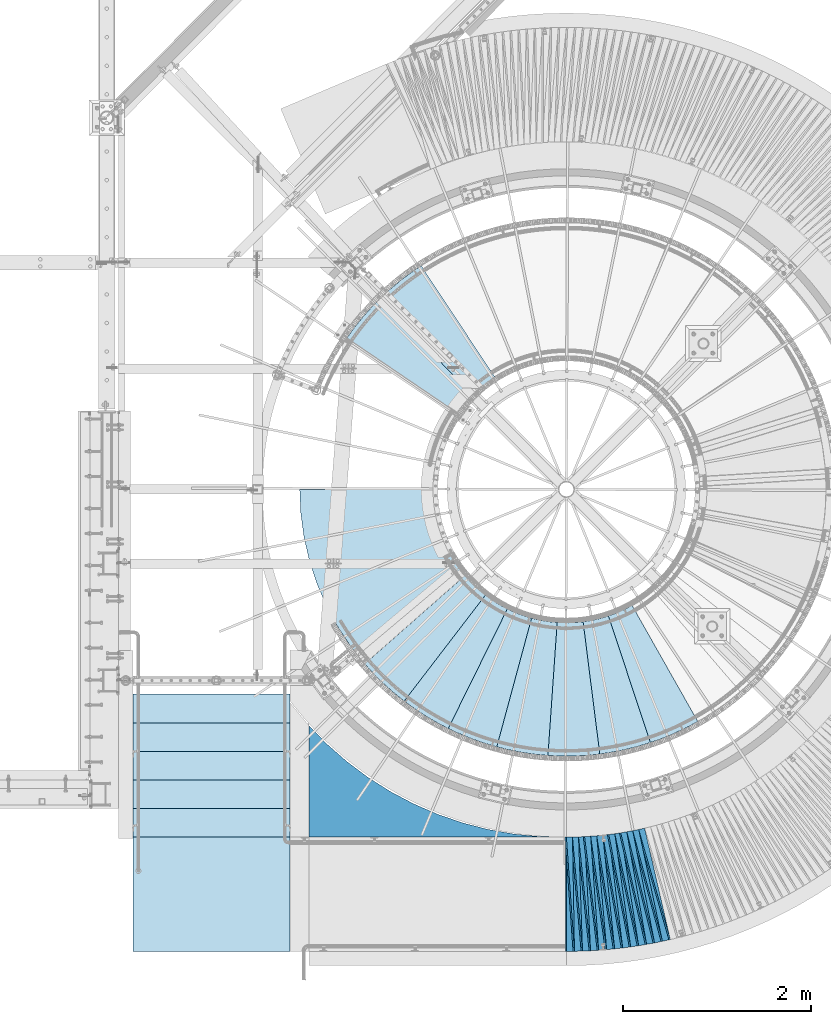
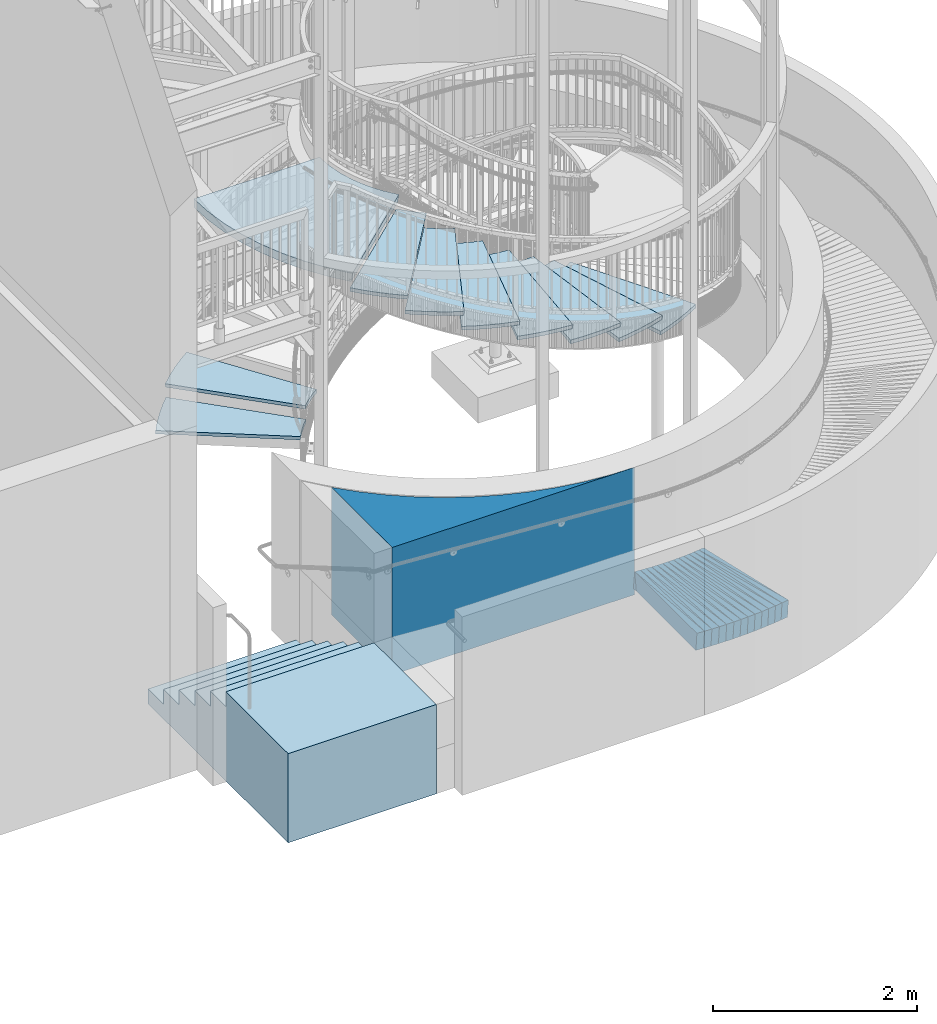
# One storey, part 830 of 975: 37 plates, 1 slab.
"""IFC2X3 building model written with IfcOpenShell, lengths in millimetres."""

from ifc_helpers import new_model, si_unit, frame, origin_with_axes, place, context, subcontext, project, spatial, faceted_brep, material, type_object, element, save


model = new_model("IFC2X3")

# Units and contexts
model_context = context("Model", 3, precision=1e-05, world=origin_with_axes())
body_context = subcontext(model_context, "Body", "Model", "MODEL_VIEW")
ifc_project = project(units=[si_unit("LENGTHUNIT", "METRE", prefix="MILLI"), si_unit("AREAUNIT", "SQUARE_METRE"), si_unit("VOLUMEUNIT", "CUBIC_METRE"), si_unit("MASSUNIT", "GRAM", prefix="KILO"), si_unit("TIMEUNIT", "SECOND"), si_unit("PLANEANGLEUNIT", "RADIAN"), si_unit("SOLIDANGLEUNIT", "STERADIAN"), si_unit("THERMODYNAMICTEMPERATUREUNIT", "DEGREE_CELSIUS"), si_unit("LUMINOUSINTENSITYUNIT", "LUMEN")], contexts=[model_context])

# Site, building, storey
site_placement = place(None, origin_with_axes())
site = spatial("IfcSite", under=ifc_project, at=site_placement, CompositionType="ELEMENT")
building_placement = place(site_placement, origin_with_axes())
building = spatial("IfcBuilding", under=site, at=building_placement, Name="Undefined", CompositionType="ELEMENT")
storey_placement = place(building_placement, origin_with_axes())
storey = spatial("IfcBuildingStorey", under=building, at=storey_placement, Name="Undefined", CompositionType="ELEMENT", Elevation=0.0)

# Plates
ifc_material_1 = material(Name="STEEL/A36")
plate_type_1 = type_object("IfcPlateType", PredefinedType="NOTDEFINED")
plate_1_placement = place(storey_placement, frame((34814.8418085716, -1523.26583017897, 780.818173331098), z_axis=(-0.99589164463732, -0.0705695748132342, 0.0567429929793393), x_axis=(-0.070455570976701, 0.997506859670101, 0.00400966699867388)))
element("IfcPlate", 1, at=plate_1_placement, inside=storey, type_object=plate_type_1, material=ifc_material_1, Name="SLAB", context=body_context, shape_type="Brep", body=[
    faceted_brep([(-6.82121026329696e-12, -100.000000000011, -1.09139364212751e-10), (6.07882642743971, -100.00000000003, 85.9247207637527), (6.07882642745199, 99.9999999999914, 85.924720763971), (5.91171556152403e-12, 100.000000000011, 1.09139364212751e-10), (1222.04675292938, -100.00000000011, -3.06317815557122e-09), (1222.04675292939, 99.9999999999113, -2.8521753847599e-09)], [[[0, 1, 2, 3]], [[1, 4, 5, 2]], [[4, 0, 3, 5]], [[5, 3, 2]], [[4, 1, 0]]]),
])
plate_2_placement = place(storey_placement, frame((34900.7386726768, -1520.36481451429, 775.918401585438), z_axis=(-0.994509342237145, -0.0879026625190699, 0.0567828330140366), x_axis=(-0.0878165980406093, 0.996128572460613, 0.00401400500185607)))
element("IfcPlate", 2, at=plate_2_placement, inside=storey, type_object=plate_type_1, material=ifc_material_1, Name="SLAB", context=body_context, shape_type="Brep", body=[
    faceted_brep([(-6.82121026329696e-12, -100.000000000011, -1.09139364212751e-10), (4.57472848894577, -99.9999999999877, 85.9702987673227), (4.57472848886573, 99.9999999999723, 85.9702987666024), (5.91171556152403e-12, 100.000000000011, 1.09139364212751e-10), (1220.72595214823, -100.000000000076, -8.80390871316195e-10), (1220.72595214815, 99.9999999998836, -1.59343471750617e-09)], [[[0, 1, 2, 3]], [[1, 4, 5, 2]], [[4, 0, 3, 5]], [[5, 3, 2]], [[4, 1, 0]]]),
])
plate_3_placement = place(storey_placement, frame((34986.633147639, -1517.46759381437, 770.924628633899), z_axis=(-0.992765436458387, -0.105208317027949, 0.0578618890266746), x_axis=(-0.105148182961202, 0.994448148633038, 0.00409136899849028)))
element("IfcPlate", 3, at=plate_3_placement, inside=storey, type_object=plate_type_1, material=ifc_material_1, Name="SLAB", context=body_context, shape_type="Brep", body=[
    faceted_brep([(-6.82121026329696e-12, -100.000000000011, -1.09139364212751e-10), (6.07985639571416, -99.9999999999991, 85.9827651977466), (6.07985639572416, 100.000000000005, 85.9827651977685), (5.91171556152403e-12, 100.000000000011, 1.09139364212751e-10), (1222.08483886739, -99.9999999998463, 3.08500602841377e-09), (1222.0848388674, 100.000000000158, 3.09955794364214e-09)], [[[0, 1, 2, 3]], [[1, 4, 5, 2]], [[4, 0, 3, 5]], [[5, 3, 2]], [[4, 1, 0]]]),
])
plate_4_placement = place(storey_placement, frame((35072.5493672218, -1511.56305616159, 766.018186772446), z_axis=(-0.990834942120358, -0.122581062974894, 0.0567450480067735), x_axis=(-0.122551484962654, 0.992454039697543, 0.00401405299877665)))
element("IfcPlate", 4, at=plate_4_placement, inside=storey, type_object=plate_type_1, material=ifc_material_1, Name="SLAB", context=body_context, shape_type="Brep", body=[
    faceted_brep([(-6.82121026329696e-12, -100.000000000011, -1.09139364212751e-10), (4.57986211779735, -99.9999999999864, 86.0271759035677), (4.57986211782099, 100.000000000027, 86.0271759036987), (5.91171556152403e-12, 100.000000000011, 1.09139364212751e-10), (1220.7114257816, -99.9999999998158, 2.6775524020195e-09), (1220.71142578162, 100.000000000197, 2.80124368146062e-09)], [[[0, 1, 2, 3]], [[1, 4, 5, 2]], [[4, 0, 3, 5]], [[5, 3, 2]], [[4, 1, 0]]]),
])
plate_5_placement = place(storey_placement, frame((35158.1341708546, -1505.67048427434, 761.02518639177), z_axis=(-0.988499067343163, -0.139679845042076, 0.0579580430200947), x_axis=(-0.139678674980385, 0.990188430860968, 0.00409134999942551)))
element("IfcPlate", 5, at=plate_5_placement, inside=storey, type_object=plate_type_1, material=ifc_material_1, Name="SLAB", context=body_context, shape_type="Brep", body=[
    faceted_brep([(-6.82121026329696e-12, -100.000000000011, -1.09139364212751e-10), (6.0497884750348, -100.000000000005, 85.8422393798173), (6.04978847509301, 100.000000000027, 85.8422393803485), (5.91171556152403e-12, 100.000000000011, 1.09139364212751e-10), (1222.09057617237, -99.9999999997922, 2.88127921521664e-09), (1222.09057617243, 100.000000000241, 3.41242412105203e-09)], [[[0, 1, 2, 3]], [[1, 4, 5, 2]], [[4, 0, 3, 5]], [[5, 3, 2]], [[4, 1, 0]]]),
])
plate_6_placement = place(storey_placement, frame((35243.6454145467, -1496.77116814638, 756.024993581713), z_axis=(-0.985897527140851, -0.157005788367976, 0.0579245060100262), x_axis=(-0.157033835972986, 0.987584729830088, 0.00409582299929533)))
element("IfcPlate", 6, at=plate_6_placement, inside=storey, type_object=plate_type_1, material=ifc_material_1, Name="SLAB", context=body_context, shape_type="Brep", body=[
    faceted_brep([(-6.82121026329696e-12, -100.000000000011, -1.09139364212751e-10), (4.5586094856335, -100.000000000005, 85.9969100952076), (4.55860948564441, 100.000000000009, 85.9969100953967), (5.91171556152403e-12, 100.000000000011, 1.09139364212751e-10), (1220.75598144561, -99.9999999998736, 1.56433088704944e-09), (1220.75598144562, 100.000000000141, 1.74622982740402e-09)], [[[0, 1, 2, 3]], [[1, 4, 5, 2]], [[4, 0, 3, 5]], [[5, 3, 2]], [[4, 1, 0]]]),
])
plate_7_placement = place(storey_placement, frame((35329.2626382773, -1487.87095399946, 751.024552463481), z_axis=(-0.983018211717351, -0.174151421680302, 0.0578487489817307), x_axis=(-0.17420864703569, 0.984700263201726, 0.00409132600083818)))
element("IfcPlate", 7, at=plate_7_placement, inside=storey, type_object=plate_type_1, material=ifc_material_1, Name="SLAB", context=body_context, shape_type="Brep", body=[
    faceted_brep([(-6.82121026329696e-12, -100.000000000011, -1.09139364212751e-10), (6.07041454307182, -100.00000000003, 86.0029678340725), (6.07041454314822, 99.9999999999959, 86.0029678344072), (5.91171556152403e-12, 100.000000000011, 1.09139364212751e-10), (1222.09777831985, -100.00000000026, -4.05270839110017e-09), (1222.09777831992, 99.9999999997663, -3.71801434084773e-09)], [[[0, 1, 2, 3]], [[1, 4, 5, 2]], [[4, 0, 3, 5]], [[5, 3, 2]], [[4, 1, 0]]]),
])
plate_8_placement = place(storey_placement, frame((35414.4795129412, -1475.95927361367, 746.118443639047), z_axis=(-0.979874549512644, -0.191365457592457, 0.0567902179765339), x_axis=(-0.191449148050867, 0.981494325260774, 0.00401412400106649)))
element("IfcPlate", 8, at=plate_8_placement, inside=storey, type_object=plate_type_1, material=ifc_material_1, Name="SLAB", context=body_context, shape_type="Brep", body=[
    faceted_brep([(-6.82121026329696e-12, -100.000000000011, -1.09139364212751e-10), (4.53406000133509, -100.00000000001, 85.9619827268471), (4.53406000145515, 100.000000000021, 85.9619827274073), (5.91171556152403e-12, 100.000000000011, 1.09139364212751e-10), (1220.68969726533, -100.000000000116, -2.16095941141248e-09), (1220.68969726545, 99.999999999915, -1.59343471750617e-09)], [[[0, 1, 2, 3]], [[1, 4, 5, 2]], [[4, 0, 3, 5]], [[5, 3, 2]], [[4, 1, 0]]]),
])
plate_9_placement = place(storey_placement, frame((35499.5843578599, -1464.17267404445, 741.124727466498), z_axis=(-0.976333263776612, -0.208382789425139, 0.0578789349824936), x_axis=(-0.208498974112779, 0.978014027529029, 0.00409142400221319)))
element("IfcPlate", 9, at=plate_9_placement, inside=storey, type_object=plate_type_1, material=ifc_material_1, Name="SLAB", context=body_context, shape_type="Brep", body=[
    faceted_brep([(-6.82121026329696e-12, -100.000000000011, -1.09139364212751e-10), (6.14620304109121, -99.9999999999932, 85.9527435303535), (6.14620304098389, 99.9999999999741, 85.9527435297568), (5.91171556152403e-12, 100.000000000011, 1.09139364212751e-10), (1222.06835937502, -100.00000000004, 1.81898940354586e-10), (1222.06835937491, 99.9999999999268, -4.22005541622639e-10)], [[[0, 1, 2, 3]], [[1, 4, 5, 2]], [[4, 0, 3, 5]], [[5, 3, 2]], [[4, 1, 0]]]),
])
plate_10_placement = place(storey_placement, frame((35584.4120636836, -1449.25507412256, 736.218159485908), z_axis=(-0.972596034504183, -0.225471725133134, 0.0567402399732852), x_axis=(-0.225611488932553, 0.974209085708751, 0.0040141479987999)))
element("IfcPlate", 10, at=plate_10_placement, inside=storey, type_object=plate_type_1, material=ifc_material_1, Name="SLAB", context=body_context, shape_type="Brep", body=[
    faceted_brep([(-6.82121026329696e-12, -100.000000000011, -1.09139364212751e-10), (4.51582622524256, -100.00000000001, 86.0389862058291), (4.51582622525166, 99.9999999999986, 86.0389862059237), (5.91171556152403e-12, 100.000000000011, 1.09139364212751e-10), (1220.68249511683, -100.00000000003, -1.63709046319127e-09), (1220.68249511684, 99.9999999999791, -1.54977897182107e-09)], [[[0, 1, 2, 3]], [[1, 4, 5, 2]], [[4, 0, 3, 5]], [[5, 3, 2]], [[4, 1, 0]]]),
])
plate_11_placement = place(storey_placement, frame((35669.0143369558, -1434.4733271338, 731.224830767501), z_axis=(-0.968457681589898, -0.242358586605843, 0.0578967569725396), x_axis=(-0.242533594900855, 0.970134380603416, 0.00409132199832751)))
element("IfcPlate", 11, at=plate_11_placement, inside=storey, type_object=plate_type_1, material=ifc_material_1, Name="SLAB", context=body_context, shape_type="Brep", body=[
    faceted_brep([(-6.82121026329696e-12, -100.000000000011, -1.09139364212751e-10), (6.10804986956828, -99.9999999999923, 85.9289932252505), (6.10804986961011, 100.000000000012, 85.9289932253887), (5.91171556152403e-12, 100.000000000011, 1.09139364212751e-10), (1222.09875488287, -99.9999999999768, 6.83940015733242e-10), (1222.09875488291, 100.000000000027, 8.29459168016911e-10)], [[[0, 1, 2, 3]], [[1, 4, 5, 2]], [[4, 0, 3, 5]], [[5, 3, 2]], [[4, 1, 0]]]),
])
plate_12_placement = place(storey_placement, frame((35753.1371062848, -1416.67710200561, 726.268699275389), z_axis=(-0.964076087687476, -0.259235288096986, 0.0579168589832335), x_axis=(-0.259439509902836, 0.965750673638307, 0.00409598199846596)))
element("IfcPlate", 12, at=plate_12_placement, inside=storey, type_object=plate_type_1, material=ifc_material_1, Name="SLAB", context=body_context, shape_type="Brep", body=[
    faceted_brep([(-6.82121026329696e-12, -100.000000000011, -1.09139364212751e-10), (4.55240583407249, -100.000000000034, 86.0086975093363), (4.55240583426712, 100.000000000015, 86.0086975099912), (5.91171556152403e-12, 100.000000000011, 1.09139364212751e-10), (1220.7084960928, -100.000000000221, -1.74622982740402e-09), (1220.708496093, 99.9999999998272, -1.09139364212751e-09)], [[[0, 1, 2, 3]], [[1, 4, 5, 2]], [[4, 0, 3, 5]], [[5, 3, 2]], [[4, 1, 0]]]),
])
plate_13_placement = place(storey_placement, frame((35837.2582014746, -1398.87622882629, 721.268646256074), z_axis=(-0.959421449901775, -0.275965837766483, 0.0579080120036786), x_axis=(-0.276199285951892, 0.961091676832601, 0.00409184099928727)))
element("IfcPlate", 13, at=plate_13_placement, inside=storey, type_object=plate_type_1, material=ifc_material_1, Name="SLAB", context=body_context, shape_type="Brep", body=[
    faceted_brep([(-6.82121026329696e-12, -100.000000000011, -1.09139364212751e-10), (6.0452780724263, -99.9999999999859, 85.9166717531916), (6.04527807225531, 99.9999999999895, 85.9166717525804), (5.91171556152403e-12, 100.000000000011, 1.09139364212751e-10), (1221.94372558624, -99.9999999999845, 7.34871719032526e-10), (1221.94372558607, 99.9999999999905, 1.23691279441118e-10)], [[[0, 1, 2, 3]], [[1, 4, 5, 2]], [[4, 0, 3, 5]], [[5, 3, 2]], [[4, 1, 0]]]),
])
plate_type_2 = type_object("IfcPlateType", PredefinedType="NOTDEFINED")
plate_14_placement = place(storey_placement, frame((34812.990061885, -1523.39711591627, 780.941014969695), z_axis=(-0.997000161101779, -0.0174209216493011, 0.0754134620072325), x_axis=(-0.0174706720028449, 0.999847376162867, 0.0)))
element("IfcPlate", 14, at=plate_14_placement, inside=storey, type_object=plate_type_2, material=ifc_material_1, Name="SLAB", context=body_context, shape_type="Brep", body=[
    faceted_brep([(-6.82121026329696e-12, -100.000000000011, -1.09139364212751e-10), (1220.31823730488, -99.9999999996576, 64.9751358076537), (1220.31823730486, 100.000000000283, 64.9751358069698), (5.91171556152403e-12, 100.000000000011, 1.09139364212751e-10), (1219.18603515645, -99.9999999996517, 4.56930138170719e-09), (1219.18603515643, 100.000000000289, 3.88536136597395e-09)], [[[0, 1, 2, 3]], [[1, 4, 5, 2]], [[4, 0, 3, 5]], [[5, 3, 2]], [[4, 1, 0]]]),
])
plate_15_placement = place(storey_placement, frame((34898.8877939268, -1520.5284799111, 776.041446591723), z_axis=(-0.996541852326296, -0.0347640385597371, 0.0754705120235196), x_axis=(-0.0348634679832343, 0.999392084519475, 0.0)))
element("IfcPlate", 15, at=plate_15_placement, inside=storey, type_object=plate_type_2, material=ifc_material_1, Name="SLAB", context=body_context, shape_type="Brep", body=[
    faceted_brep([(-6.82121026329696e-12, -100.000000000011, -1.09139364212751e-10), (1218.99816894534, -100.000000000029, 64.9260177608448), (1218.99816894536, 100.000000000012, 64.9260177614706), (5.91171556152403e-12, 100.000000000011, 1.09139364212751e-10), (1219.04101562503, -100.000000000035, -4.58385329693556e-10), (1219.04101562505, 100.000000000007, 1.60071067512035e-10)], [[[0, 1, 2, 3]], [[1, 4, 5, 2]], [[4, 0, 3, 5]], [[5, 3, 2]], [[4, 1, 0]]]),
])
plate_16_placement = place(storey_placement, frame((34984.7389413909, -1517.66840742829, 771.053285059365), z_axis=(-0.995663531517368, -0.0521752225931188, 0.0770186870423087), x_axis=(-0.0523306630077133, 0.998629812147211, 0.0)))
element("IfcPlate", 16, at=plate_16_placement, inside=storey, type_object=plate_type_2, material=ifc_material_1, Name="SLAB", context=body_context, shape_type="Brep", body=[
    faceted_brep([(-6.82121026329696e-12, -100.000000000011, -1.09139364212751e-10), (1220.35681152316, -100.000000000205, 64.9160003634752), (1220.35681152318, 99.9999999998349, 64.9160003640791), (5.91171556152403e-12, 100.000000000011, 1.09139364212751e-10), (1219.17224121067, -100.000000000208, -4.02360456064343e-09), (1219.17224121068, 99.9999999998308, -3.41242412105203e-09)], [[[0, 1, 2, 3]], [[1, 4, 5, 2]], [[4, 0, 3, 5]], [[5, 3, 2]], [[4, 1, 0]]]),
])
plate_17_placement = place(storey_placement, frame((35070.7041931486, -1511.79140204759, 766.141247896455), z_axis=(-0.994723175908695, -0.0695267408896928, 0.0754442549925269), x_axis=(-0.0697254569775532, 0.997566218678876, 0.0)))
element("IfcPlate", 17, at=plate_17_placement, inside=storey, type_object=plate_type_2, material=ifc_material_1, Name="SLAB", context=body_context, shape_type="Brep", body=[
    faceted_brep([(-6.82121026329696e-12, -100.000000000011, -1.09139364212751e-10), (1218.98242187483, -100.000000000229, 64.9486160247106), (1218.98242187482, 99.9999999997476, 64.9486160245069), (5.91171556152403e-12, 100.000000000011, 1.09139364212751e-10), (1219.06689453108, -100.000000000223, -3.17231751978397e-09), (1219.06689453107, 99.9999999997531, -3.36149241775274e-09)], [[[0, 1, 2, 3]], [[1, 4, 5, 2]], [[4, 0, 3, 5]], [[5, 3, 2]], [[4, 1, 0]]]),
])
plate_18_placement = place(storey_placement, frame((35156.2482633389, -1505.93704782468, 761.154014259341), z_axis=(-0.993232909847741, -0.0868445048202271, 0.0771130259937943), x_axis=(-0.0871038690083007, 0.996199235094961, 0.0)))
element("IfcPlate", 18, at=plate_18_placement, inside=storey, type_object=plate_type_2, material=ifc_material_1, Name="SLAB", context=body_context, shape_type="Brep", body=[
    faceted_brep([(-6.82121026329696e-12, -100.000000000011, -1.09139364212751e-10), (1220.36938476577, -99.999999999899, 64.839889527575), (1220.36938476573, 100.00000000006, 64.8398895271675), (5.91171556152403e-12, 100.000000000011, 1.09139364212751e-10), (1219.23400878922, -99.9999999998868, 1.65891833603382e-09), (1219.23400878919, 100.000000000073, 1.25874066725373e-09)], [[[0, 1, 2, 3]], [[1, 4, 5, 2]], [[4, 0, 3, 5]], [[5, 3, 2]], [[4, 1, 0]]]),
])
plate_19_placement = place(storey_placement, frame((35241.7742023656, -1497.06923665448, 756.152997226941), z_axis=(-0.991581588464759, -0.10411443077308, 0.0769814180338583), x_axis=(-0.104424307012338, 0.994532837117505, 0.0)))
element("IfcPlate", 19, at=plate_19_placement, inside=storey, type_object=plate_type_2, material=ifc_material_1, Name="SLAB", context=body_context, shape_type="Brep", body=[
    faceted_brep([(-6.82121026329696e-12, -100.000000000011, -1.09139364212751e-10), (1219.02697753922, -99.9999999998763, 64.9507370010688), (1219.02697753928, 100.000000000155, 64.9507370014908), (5.91171556152403e-12, 100.000000000011, 1.09139364212751e-10), (1219.06481933608, -99.9999999998895, 1.70257408171892e-09), (1219.06481933614, 100.000000000142, 2.11730366572738e-09)], [[[0, 1, 2, 3]], [[1, 4, 5, 2]], [[4, 0, 3, 5]], [[5, 3, 2]], [[4, 1, 0]]]),
])
plate_20_placement = place(storey_placement, frame((35327.3753182, -1488.20538826357, 751.154102262059), z_axis=(-0.989588009904639, -0.121521179066264, 0.077124403993303), x_axis=(-0.121884213957511, 0.992544325654003, 0.0)))
element("IfcPlate", 20, at=plate_20_placement, inside=storey, type_object=plate_type_2, material=ifc_material_1, Name="SLAB", context=body_context, shape_type="Brep", body=[
    faceted_brep([(-6.82121026329696e-12, -100.000000000011, -1.09139364212751e-10), (1220.37695312503, -100.00000000004, 64.8303222651084), (1220.37695312501, 99.9999999999595, 64.8303222649847), (5.91171556152403e-12, 100.000000000011, 1.09139364212751e-10), (1219.18994140627, -100.000000000053, -7.20319803804159e-10), (1219.18994140625, 99.9999999999468, -8.36735125631094e-10)], [[[0, 1, 2, 3]], [[1, 4, 5, 2]], [[4, 0, 3, 5]], [[5, 3, 2]], [[4, 1, 0]]]),
])
plate_21_placement = place(storey_placement, frame((35412.6552228301, -1476.31562102562, 746.241552881295), z_axis=(-0.987448085546927, -0.138738460641732, 0.0754845539727948), x_axis=(-0.1391354180007, 0.990273364004996, 0.0)))
element("IfcPlate", 21, at=plate_21_placement, inside=storey, type_object=plate_type_2, material=ifc_material_1, Name="SLAB", context=body_context, shape_type="Brep", body=[
    faceted_brep([(-6.82121026329696e-12, -100.000000000011, -1.09139364212751e-10), (1218.96252441406, -99.9999999999559, 64.913940430386), (1218.96252441402, 100.00000000004, 64.9139404301968), (5.91171556152403e-12, 100.000000000011, 1.09139364212751e-10), (1218.95629882815, -99.9999999999354, 7.27595761418343e-10), (1218.95629882811, 100.000000000061, 5.5297277867794e-10)], [[[0, 1, 2, 3]], [[1, 4, 5, 2]], [[4, 0, 3, 5]], [[5, 3, 2]], [[4, 1, 0]]]),
])
plate_22_placement = place(storey_placement, frame((35497.7222833487, -1464.57018050876, 741.253355603438), z_axis=(-0.984757216734612, -0.155948514558953, 0.0770278189744195), x_axis=(-0.156413227021042, 0.987691704132855, 0.0)))
element("IfcPlate", 22, at=plate_22_placement, inside=storey, type_object=plate_type_2, material=ifc_material_1, Name="SLAB", context=body_context, shape_type="Brep", body=[
    faceted_brep([(-6.82121026329696e-12, -100.000000000011, -1.09139364212751e-10), (1220.34326171885, -99.9999999999613, 64.9116134648284), (1220.34326171885, 100.000000000023, 64.9116134647193), (5.91171556152403e-12, 100.000000000011, 1.09139364212751e-10), (1219.20629882823, -99.99999999996, 5.96628524363041e-10), (1219.20629882823, 100.000000000025, 4.80213202536106e-10)], [[[0, 1, 2, 3]], [[1, 4, 5, 2]], [[4, 0, 3, 5]], [[5, 3, 2]], [[4, 1, 0]]]),
])
plate_23_placement = place(storey_placement, frame((35582.5925859047, -1449.67694620695, 736.341853859415), z_axis=(-0.981992381803066, -0.173167669876962, 0.0755243019836927), x_axis=(-0.173663659988658, 0.984805022935679, 0.0)))
element("IfcPlate", 23, at=plate_23_placement, inside=storey, type_object=plate_type_2, material=ifc_material_1, Name="SLAB", context=body_context, shape_type="Brep", body=[
    faceted_brep([(-6.82121026329696e-12, -100.000000000011, -1.09139364212751e-10), (1218.95715332032, -100.000000000007, 64.8797760009038), (1218.95715332038, 100.000000000026, 64.8797760013113), (5.91171556152403e-12, 100.000000000011, 1.09139364212751e-10), (1219.02307128911, -99.9999999999895, 8.22183210402727e-10), (1219.02307128917, 100.000000000044, 1.23691279441118e-09)], [[[0, 1, 2, 3]], [[1, 4, 5, 2]], [[4, 0, 3, 5]], [[5, 3, 2]], [[4, 1, 0]]]),
])
plate_24_placement = place(storey_placement, frame((35667.1743124976, -1434.93387349566, 731.352934211377), z_axis=(-0.978720112202225, -0.190215824337768, 0.0769732560203004), x_axis=(-0.190781843953357, 0.981632460760012, 0.0)))
element("IfcPlate", 24, at=plate_24_placement, inside=storey, type_object=plate_type_2, material=ifc_material_1, Name="SLAB", context=body_context, shape_type="Brep", body=[
    faceted_brep([(-6.82121026329696e-12, -100.000000000011, -1.09139364212751e-10), (1220.37121581964, -100.000000000275, 64.9576263392737), (1220.3712158196, 99.9999999997194, 64.9576263391209), (5.91171556152403e-12, 100.000000000011, 1.09139364212751e-10), (1219.19360351495, -100.00000000027, -7.08678271621466e-09), (1219.19360351492, 99.9999999997235, -7.23230186849833e-09)], [[[0, 1, 2, 3]], [[1, 4, 5, 2]], [[4, 0, 3, 5]], [[5, 3, 2]], [[4, 1, 0]]]),
])
plate_25_placement = place(storey_placement, frame((35751.3002637484, -1417.17109708092, 726.397251870166), z_axis=(-0.975245226469414, -0.207269261374567, 0.0770467490414994), x_axis=(-0.207887209994317, 0.978152803973274, 0.0)))
element("IfcPlate", 25, at=plate_25_placement, inside=storey, type_object=plate_type_2, material=ifc_material_1, Name="SLAB", context=body_context, shape_type="Brep", body=[
    faceted_brep([(-6.82121026329696e-12, -100.000000000011, -1.09139364212751e-10), (1218.98217773466, -99.9999999998677, 64.8956680314877), (1218.98217773465, 100.000000000125, 64.8956680314514), (5.91171556152403e-12, 100.000000000011, 1.09139364212751e-10), (1218.9301757815, -99.9999999998827, 2.42289388552308e-09), (1218.93017578149, 100.00000000011, 2.40106601268053e-09)], [[[0, 1, 2, 3]], [[1, 4, 5, 2]], [[4, 0, 3, 5]], [[5, 3, 2]], [[4, 1, 0]]]),
])
plate_26_placement = place(storey_placement, frame((35835.4306960123, -1399.4019658704, 721.397144463169), z_axis=(-0.97148343959215, -0.22424510424361, 0.077032848973529), x_axis=(-0.224913422028694, 0.974378752124318, 0.0)))
element("IfcPlate", 26, at=plate_26_placement, inside=storey, type_object=plate_type_2, material=ifc_material_1, Name="SLAB", context=body_context, shape_type="Brep", body=[
    faceted_brep([(-6.82121026329696e-12, -100.000000000011, -1.09139364212751e-10), (1220.21862792875, -100.000000000291, 64.9073715172053), (1220.21862792879, 99.9999999997221, 64.9073715174673), (5.91171556152403e-12, 100.000000000011, 1.09139364212751e-10), (1219.13574218656, -100.000000000291, -4.54747350886464e-09), (1219.1357421866, 99.9999999997212, -4.29281499236822e-09)], [[[0, 1, 2, 3]], [[1, 4, 5, 2]], [[4, 0, 3, 5]], [[5, 3, 2]], [[4, 1, 0]]]),
])
ifc_material_2 = material(Name="STEEL/Zero_Density")
plate_type_3 = type_object("IfcPlateType", PredefinedType="NOTDEFINED")
for number, where, z_axis, x_axis, name in (
    (27, (35435.4313884155, 2165.82981109354, 2822.575), (0.445576380168365, -0.895243927338274, 0.0), (-0.895243927338273, -0.445576380168367, 0.0), "CONC."),
    (28, (35182.5131259902, 2053.53922701531, 3000.375), (0.263809436003758, -0.964574819013735, 0.0), (-0.964574819013735, -0.263809436003756, 0.0), "CONC."),
    (29, (34912.6393612634, 1992.34303552462, 3178.175), (0.0720583610280373, -0.997400417388098, 0.0), (-0.997400417388098, -0.0720583610280383, 0.0), "CONC."),
    (30, (34636.0237352501, 1984.55726734799, 3355.975), (-0.122419833990949, -0.99247840492659, 0.0), (-0.99247840492659, 0.122419833990946, 0.0), "CONC."),
    (31, (34363.1350414108, 2030.47658262499, 3533.775), (-0.312264928111909, -0.949995060340455, 0.0), (-0.949995060340455, 0.31226492811191, 0.0), "CONC."),
    (32, (34104.3010237513, 2128.36311920227, 3711.575), (-0.490292045925708, -0.871558207867945, 0.0), (-0.871558207867944, 0.490292045925709, 0.0), "CONC."),
    (33, (33869.3175130802, 2274.512263755, 3889.375), (-0.649763573982622, -0.760136367979674, 0.0), (-0.760136367979675, 0.649763573982621, 0.0), "CONC."),
    (34, (33557.7321040196, 4202.72275077197, 155.575), (-0.796088846887248, 0.605179764914304, 0.0), (0.605179764914303, 0.796088846887248, 0.0), "CONC."),
    (35, (33734.7245969666, 4415.44435329796, 333.375), (-0.663850787919022, 0.747865048908755, 0.0), (0.747865048908755, 0.663850787919022, 0.0), "CONC."),
):
    element("IfcPlate", number, at=place(storey_placement, frame(where, z_axis=z_axis, x_axis=x_axis)), inside=storey, type_object=plate_type_3, material=ifc_material_2, Name=name, context=body_context, shape_type="Brep", body=[
        faceted_brep([(226.607026755963, -22.2249999999999, -5.9806827134089), (151.21244687953, -22.2249999999999, 0.0171956564081484), (151.21244687953, 22.2249999999999, 0.0171956564081484), (226.607026755963, 22.2249999999999, -5.9806827134089), (75.6059955448145, -22.2249999999999, 2.01262449634305), (75.6059955448145, 22.2249999999999, 2.01262449634305), (0.0, -22.2249999999999, 0.0), (6.3512526843333, 22.2249999999999, 0.169069749597838), (-75.9923477177144, -22.2249999999999, 1420.59179687598), (-69.6411756631605, 22.2249999999999, 1420.76237488879), (75.2887648406067, -22.2249999999999, 1424.6548629265), (75.2887648406067, 22.2249999999999, 1424.6548629265), (226.570657118533, -22.2249999999999, 1420.62093290526), (226.570657118533, 22.2249999999999, 1420.62093290526), (377.420264969449, -22.2249999999999, 1408.50155446305), (377.420264969449, 22.2249999999999, 1408.50155446305), (501.974970329931, -22.2249999999999, 1391.75136796272), (501.974970329931, 22.2249999999999, 1391.75136796272), (301.578002929167, 22.2249999999999, -15.9641666403222), (301.578002929167, -22.2249999999999, -15.9641666403222)], [[[0, 1, 2, 3]], [[1, 4, 5, 2]], [[5, 4, 6, 7]], [[8, 9, 7, 6]], [[10, 11, 9, 8]], [[10, 12, 13, 11]], [[12, 14, 15, 13]], [[15, 14, 16, 17]], [[3, 2, 5, 7, 9, 11, 13, 15, 17, 18]], [[0, 3, 18, 19]], [[14, 12, 10, 8, 6, 4, 1, 0, 19, 16]], [[18, 17, 16, 19]]]),
    ])
plate_type_4 = type_object("IfcPlateType", PredefinedType="NOTDEFINED")
plate_27_placement = place(storey_placement, frame((31991.3000139725, 881.301693584519, 1371.6), z_axis=(1.0, 0.0, 0.0), x_axis=(0.0, -1.0, 0.0)))
element("IfcPlate", 36, at=plate_27_placement, inside=storey, type_object=plate_type_4, material=ifc_material_1, Name="WALL", context=body_context, shape_type="Brep", body=[
    faceted_brep([(-1.13686837721616e-13, -762.0, -3.63797880709171e-12), (200.063353692296, -762.0, 195.948669721995), (200.063353692296, 762.0, 195.948669721995), (-1.13686837721616e-13, 762.0, -3.63797880709171e-12), (384.347611822462, -762.0, 406.805348206941), (384.347611822462, 762.0, 406.805348206941), (551.745421020083, -762.0, 631.303009958978), (551.745421020083, 762.0, 631.303009958978), (701.25089760253, -762.0, 868.092661608196), (701.25089760253, 762.0, 868.092661608196), (831.965671871427, -762.0, 1115.75144793354), (831.965671871427, 762.0, 1115.75144793354), (943.104286363825, -762.0, 1372.79120171695), (943.104286363825, 762.0, 1372.79120171695), (1033.99891562034, -762.0, 1637.66738605344), (1033.99891562034, 762.0, 1637.66738605344), (1104.10337910941, -762.0, 1908.78837538342), (1104.10337910941, 762.0, 1908.78837538342), (1152.99642319434, -762.0, 2184.52501947791), (1152.99642319434, 762.0, 2184.52501947791), (1180.38425242178, -762.0, 2463.22043290735), (1180.38425242178, 762.0, 2463.22043290735), (1186.10229492178, -762.0, 2743.1999511699), (1186.10229492178, 762.0, 2743.1999511699), (1186.10229492188, -762.0, -1.95723259821534e-09), (1186.10229492188, 762.0, -1.95723259821534e-09)], [[[0, 1, 2, 3]], [[1, 4, 5, 2]], [[4, 6, 7, 5]], [[6, 8, 9, 7]], [[8, 10, 11, 9]], [[10, 12, 13, 11]], [[12, 14, 15, 13]], [[14, 16, 17, 15]], [[16, 18, 19, 17]], [[18, 20, 21, 19]], [[20, 22, 23, 21]], [[22, 24, 25, 23]], [[24, 0, 3, 25]], [[5, 7, 9, 11, 13, 15, 17, 19, 21, 23, 25, 3, 2]], [[24, 22, 20, 18, 16, 14, 12, 10, 8, 6, 4, 1, 0]]]),
])

# Slab
ifc_material_3 = material(Name="CONCRETE/3000")
slab_type = type_object("IfcSlabType", PredefinedType="NOTDEFINED")
slab_placement = place(storey_placement, frame((30949.9, 1063.74595588377, 2.27373675443232e-13), z_axis=(0.0, -2.11599999988721e-06, 0.999999999997761), x_axis=(0.0, 0.999999999997761, 2.11599999999526e-06)))
element("IfcSlab", 37, at=slab_placement, inside=storey, type_object=slab_type, material=ifc_material_3, Name="STAIR", PredefinedType="FLOOR", context=body_context, shape_type="Brep", body=[
    faceted_brep([(2.27373675443232e-13, -838.200000000001, -4.33680868994202e-19), (-2587.74584960928, -838.200000000001, 0.00547966547310333), (-2587.74584960928, 838.200000000001, 0.00547966547310333), (2.27373675443232e-13, 838.200000000001, -4.33680868994202e-19), (-2587.74365234356, -838.200000000001, 1066.80554199219), (-2587.74365234356, 838.200000000001, 1066.80554199219), (-1368.54357910141, -838.200000000001, 1066.80297851563), (-1368.54357910141, 838.200000000001, 1066.80297851563), (-1368.54382324206, -838.200000000001, 889.002990722656), (-1368.54382324206, 838.200000000001, 889.002990722656), (-1063.74377441394, -838.200000000001, 889.00244140625), (-1063.74377441394, 838.200000000001, 889.00244140625), (-1063.74426269521, -838.200000000001, 711.202392578125), (-1063.74426269521, 838.200000000001, 711.202392578125), (-758.944152831937, -838.200000000001, 711.201721191406), (-758.944152831937, 838.200000000001, 711.201721191406), (-758.944519042892, -838.200000000001, 533.401733398438), (-758.944519042892, 838.200000000001, 533.401733398438), (-454.144653320246, -838.200000000001, 533.401123046875), (-454.144653320246, 838.200000000001, 533.401123046875), (-454.144958496044, -838.200000000001, 355.60107421875), (-454.144958496044, 838.200000000001, 355.60107421875), (-149.344924926719, -838.200000000001, 355.600463867188), (-149.344924926719, 838.200000000001, 355.600463867188), (-149.345306396462, -838.200000000001, 177.800430297852), (-149.345306396462, 838.200000000001, 177.800430297852), (155.454696655285, -838.200000000001, 177.799789428711), (155.454696655285, 838.200000000001, 177.799789428711), (155.454284667964, -838.200000000001, -0.000230021163588379), (155.454284667964, 838.200000000001, -0.000230021163588379), (44.5729866027818, -838.200000000001, 4.96441169423045e-12), (44.5729866027818, 838.200000000001, 4.96441169423045e-12)], [[[0, 1, 2, 3]], [[1, 4, 5, 2]], [[4, 6, 7, 5]], [[6, 8, 9, 7]], [[8, 10, 11, 9]], [[10, 12, 13, 11]], [[12, 14, 15, 13]], [[14, 16, 17, 15]], [[16, 18, 19, 17]], [[18, 20, 21, 19]], [[20, 22, 23, 21]], [[22, 24, 25, 23]], [[24, 26, 27, 25]], [[26, 28, 29, 27]], [[28, 30, 31, 29]], [[30, 0, 3, 31]], [[5, 7, 9, 11, 13, 15, 17, 19, 21, 23, 25, 27, 29, 31, 3, 2]], [[30, 28, 26, 24, 22, 20, 18, 16, 14, 12, 10, 8, 6, 4, 1, 0]]]),
])

# Plate
plate_type_5 = type_object("IfcPlateType", PredefinedType="NOTDEFINED")
plate_28_placement = place(storey_placement, frame((33312.1, 3403.59999999999, 4038.6), z_axis=(-0.988628882676091, -0.150375969950732, 0.0), x_axis=(0.150375969950731, -0.988628882676091, 0.0)))
element("IfcPlate", 38, at=plate_28_placement, inside=storey, type_object=plate_type_5, material=ifc_material_1, Name="CONC.", context=body_context, shape_type="Brep", body=[
    faceted_brep([(1751.97585217421, 50.8000000008574, 987.234705496721), (1739.40643698892, -50.8000000000002, 994.52791194724), (970.231496607658, -50.8000000000002, -202.411566436138), (982.770874022934, 50.8000000000002, -209.436737057673), (833.535273557532, -50.8000000000002, -125.827677264882), (675.3453554734, -50.8000000000002, -60.7301416567207), (675.3453554734, 50.8000000000002, -60.7301416567207), (833.535273557532, 50.8000000000002, -125.827677264882), (510.487094904177, -50.8000000000002, -15.0848434560248), (510.487094904177, 50.8000000000002, -15.0848434560248), (341.34283004689, -50.8000000000002, 10.4486050312044), (341.34283004689, 50.8000000000002, 10.4486050312044), (170.356835404899, -50.8000000000002, 15.50122435909), (170.356835404899, 50.8000000000002, 15.50122435909), (0.0, -50.799999999992, 1.81898940354586e-11), (0.0, 50.799999999992, -1.45519152283669e-11), (-213.894775390134, -50.8000000000002, 1406.2257080053), (-213.894775390134, 50.8000000000002, 1406.2257080053), (41.3707023131378, -50.8000000000002, 1433.31180178729), (41.3707023131378, 50.8000000000002, 1433.31180178729), (298.038313330295, -50.8000000000002, 1437.29401702172), (298.038313330295, 50.8000000000002, 1437.29401702172), (554.021209830597, -50.8000000000002, 1418.13997612411), (554.021209830597, 50.8000000000002, 1418.13997612411), (807.238111086232, -50.8000000000002, 1376.00541190602), (807.238111086232, 50.8000000000002, 1376.00541190602), (1055.63022542109, -50.8000000000002, 1311.23290138208), (1055.63022542109, 50.8000000000002, 1311.23290138208), (1297.17798931131, -50.8000000000002, 1224.34908043184), (1297.17798931131, 50.8000000000002, 1224.34908043184), (1529.91748753949, -50.8000000000002, 1116.06036196246), (1529.91748753949, 50.8000000000002, 1116.06036196246)], [[[0, 1, 2, 3]], [[4, 5, 6, 7]], [[5, 8, 9, 6]], [[8, 10, 11, 9]], [[10, 12, 13, 11]], [[12, 14, 15, 13]], [[14, 16, 17, 15]], [[16, 18, 19, 17]], [[18, 20, 21, 19]], [[20, 22, 23, 21]], [[22, 24, 25, 23]], [[24, 26, 27, 25]], [[26, 28, 29, 27]], [[28, 30, 31, 29]], [[7, 6, 9, 11, 13, 15, 17, 19, 21, 23, 25, 27, 29, 31, 0, 3]], [[4, 7, 3, 2]], [[30, 28, 26, 24, 22, 20, 18, 16, 14, 12, 10, 8, 5, 4, 2, 1]], [[31, 30, 1, 0]]]),
])

save(model, "model.ifc")
